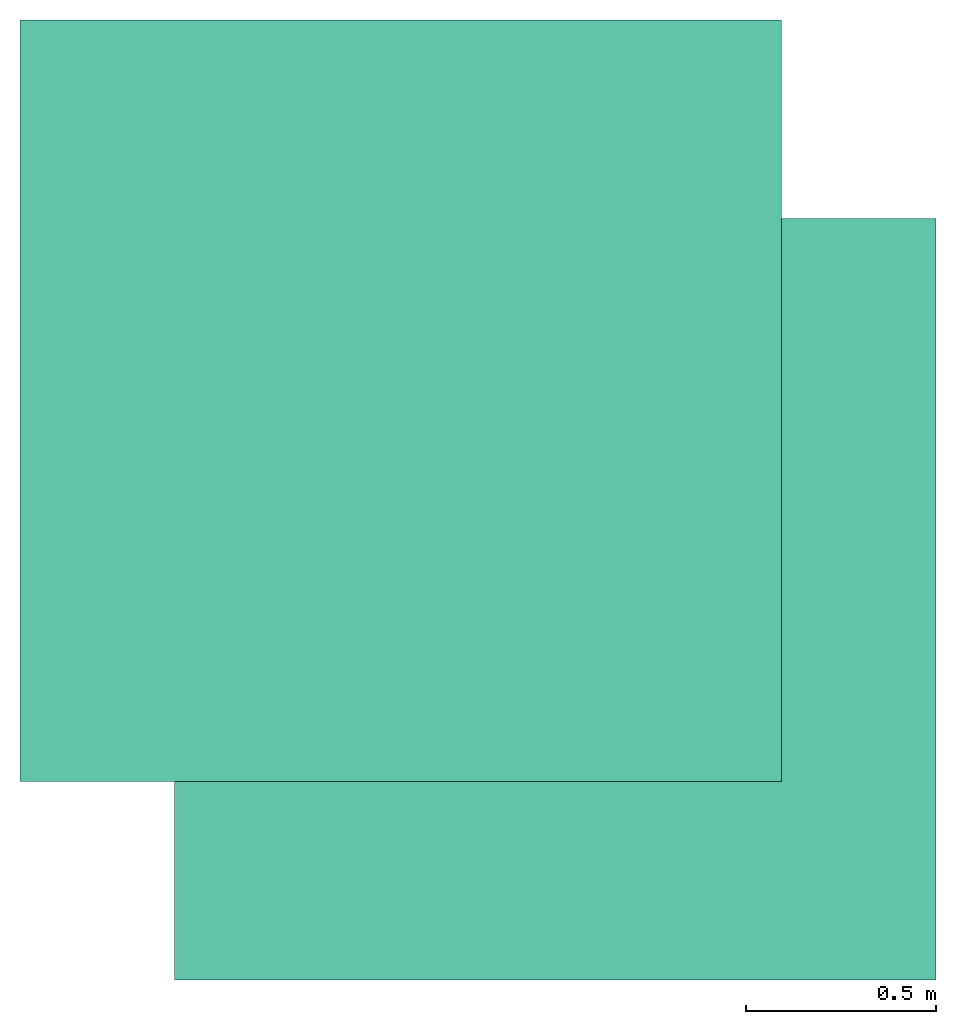
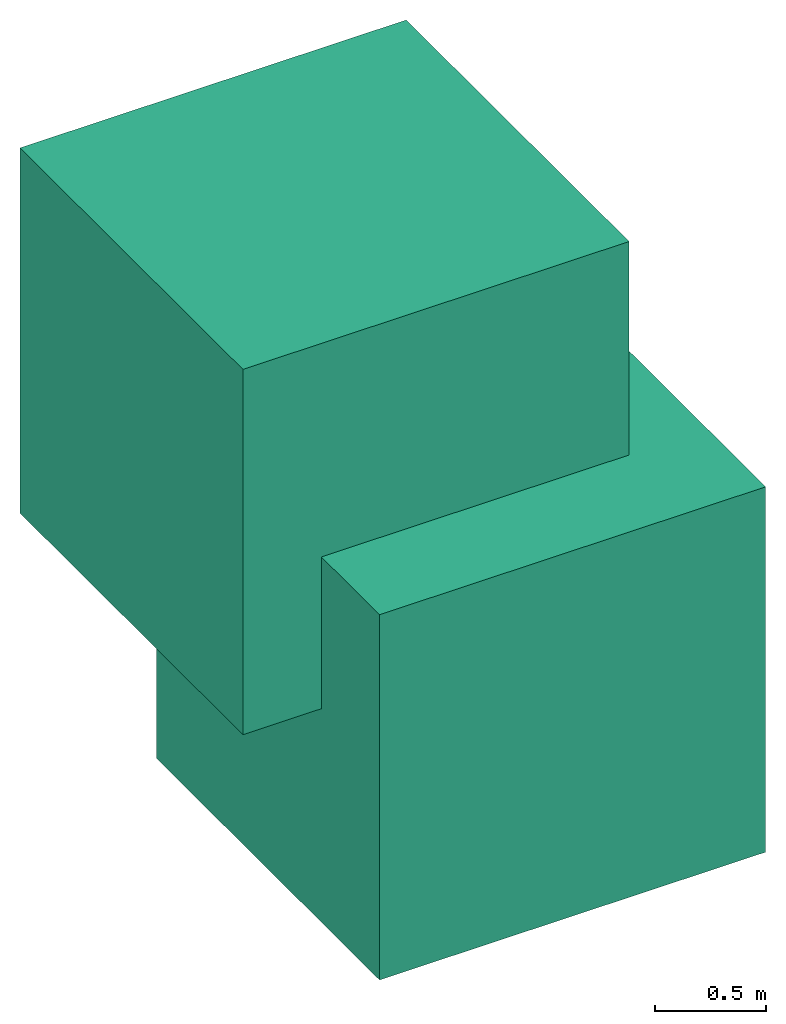
# One storey: 2 actuators.
"""IFC4 building model written with IfcOpenShell, lengths in metres."""

from ifc_helpers import new_model, entity, si_unit, converted_unit, frame, frame_2d, origin_with_axes, place, context, subcontext, project, spatial, polygons, element, save


model = new_model("IFC4")

# Units and contexts
model_context = context("Model", 3, precision=1e-05, world=origin_with_axes())
plan_context = context("Plan", 2, precision=1e-05, world=frame_2d((0.0, 0.0, 0.0), x_axis=(1.0, 0.0, 0.0)))
body_context = subcontext(model_context, "Body", "Model", "MODEL_VIEW")
ifc_project = project(units=[converted_unit("PLANEANGLEUNIT", "degree", entity("IfcReal", 0.0174532925199433), si_unit("PLANEANGLEUNIT", "RADIAN"), dimensions=[0, 0, 0, 0, 0, 0, 0]), si_unit("AREAUNIT", "SQUARE_METRE"), si_unit("VOLUMEUNIT", "CUBIC_METRE"), si_unit("LENGTHUNIT", "METRE")], contexts=[model_context, plan_context])

# Site, building, storey
site_placement = place(None, origin_with_axes())
site = spatial("IfcSite", under=ifc_project, at=site_placement)
building_placement = place(site_placement, origin_with_axes())
building = spatial("IfcBuilding", under=site, at=building_placement, Name="Building")
storey_placement = place(building_placement, origin_with_axes())
storey = spatial("IfcBuildingStorey", under=building, at=storey_placement, Name="Storey")

# Actuators
for number, where, z_axis, x_axis, name in (
    (1, (0.0, 0.0, 0.0), (0.0, 0.0, 1.0), (1.0, 0.0, 0.0), "Cube1"),
    (2, (-0.405904978513718, 0.521775722503662, 1.16886925697327), (0.0, 0.0, 1.0), (1.0, 0.0, 0.0), "Cube2"),
):
    element("IfcActuator", number, at=place(storey_placement, frame(where, z_axis=z_axis, x_axis=x_axis)), inside=storey, Name=name, PredefinedType="ELECTRICACTUATOR", context=body_context, shape_type="Tessellation", body=[
        polygons([(-1.0, -1.0, -1.0), (-1.0, -1.0, 1.0), (-1.0, 1.0, -1.0), (-1.0, 1.0, 1.0), (1.0, -1.0, -1.0), (1.0, -1.0, 1.0), (1.0, 1.0, -1.0), (1.0, 1.0, 1.0)], [[[1, 2, 4, 3]], [[3, 4, 8, 7]], [[7, 8, 6, 5]], [[5, 6, 2, 1]], [[3, 7, 5, 1]], [[8, 4, 2, 6]]]),
    ])

save(model, "model.ifc")
